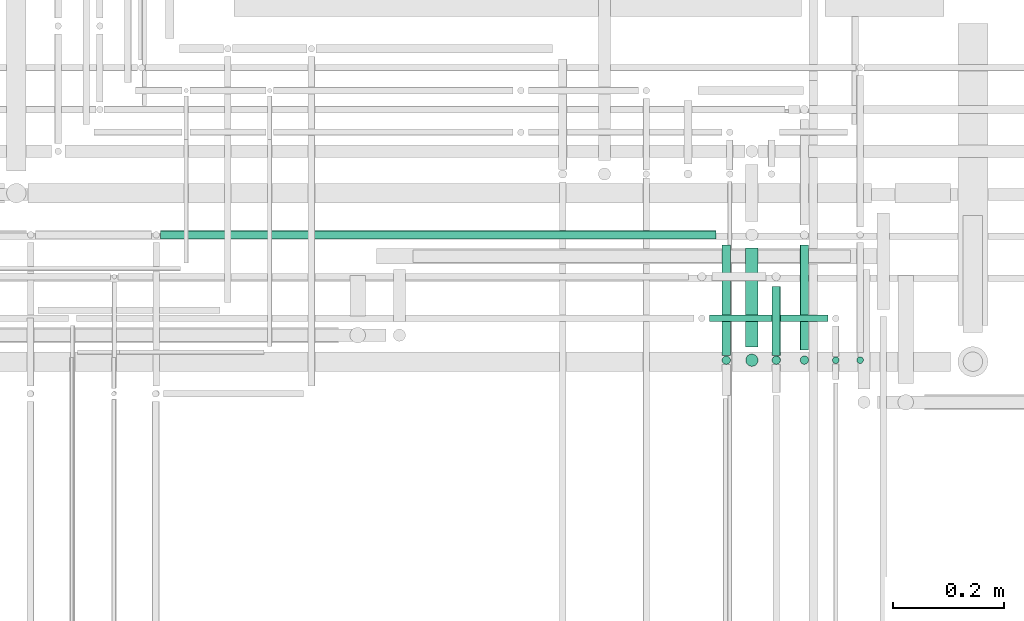
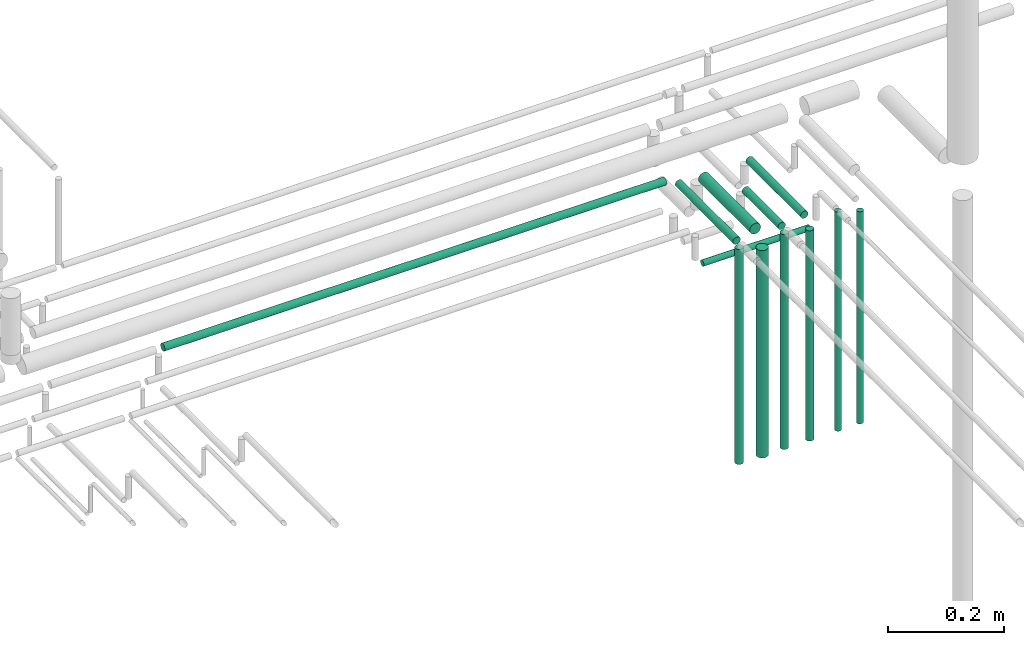
# One storey, part 222 of 331: 12 flow segments.
"""IFC2X3 building model written with IfcOpenShell, lengths in millimetres."""

from ifc_helpers import new_model, entity, si_unit, converted_unit, derived_unit, direction, frame, frame_2d, origin, origin_2d_with_axis, place, context, subcontext, project, spatial, circle, extrude, type_object, element, save


model = new_model("IFC2X3")

# Units and contexts
model_context = context("Model", 3, precision=0.01, world=origin(), true_north=direction((6.12303176911189e-17, 1.0)))
body_context = subcontext(model_context, "Body", "Model", "MODEL_VIEW")
ifc_project = project(units=[si_unit("LENGTHUNIT", "METRE", prefix="MILLI"), si_unit("AREAUNIT", "SQUARE_METRE"), si_unit("VOLUMEUNIT", "CUBIC_METRE"), converted_unit("PLANEANGLEUNIT", "DEGREE", entity("IfcRatioMeasure", 0.0174532925199433), si_unit("PLANEANGLEUNIT", "RADIAN"), dimensions=[0, 0, 0, 0, 0, 0, 0]), si_unit("MASSUNIT", "GRAM", prefix="KILO"), derived_unit("MASSDENSITYUNIT", [(si_unit("MASSUNIT", "GRAM", prefix="KILO"), 1), (si_unit("LENGTHUNIT", "METRE"), -3)]), derived_unit("MOMENTOFINERTIAUNIT", [(si_unit("LENGTHUNIT", "METRE"), 4)]), si_unit("TIMEUNIT", "SECOND"), si_unit("FREQUENCYUNIT", "HERTZ"), si_unit("THERMODYNAMICTEMPERATUREUNIT", "DEGREE_CELSIUS"), derived_unit("THERMALTRANSMITTANCEUNIT", [(si_unit("MASSUNIT", "GRAM", prefix="KILO"), 1), (si_unit("THERMODYNAMICTEMPERATUREUNIT", "KELVIN"), -1), (si_unit("TIMEUNIT", "SECOND"), -3)]), derived_unit("VOLUMETRICFLOWRATEUNIT", [(si_unit("LENGTHUNIT", "METRE"), 3), (si_unit("TIMEUNIT", "SECOND"), -1)]), derived_unit("MASSFLOWRATEUNIT", [(si_unit("MASSUNIT", "GRAM", prefix="KILO"), 1), (si_unit("TIMEUNIT", "SECOND"), -1)]), derived_unit("ROTATIONALFREQUENCYUNIT", [(si_unit("TIMEUNIT", "SECOND"), -1)]), si_unit("ELECTRICCURRENTUNIT", "AMPERE"), si_unit("ELECTRICVOLTAGEUNIT", "VOLT"), si_unit("POWERUNIT", "WATT"), si_unit("FORCEUNIT", "NEWTON", prefix="KILO"), si_unit("ILLUMINANCEUNIT", "LUX"), si_unit("LUMINOUSFLUXUNIT", "LUMEN"), si_unit("LUMINOUSINTENSITYUNIT", "CANDELA"), derived_unit("USERDEFINED", [(si_unit("MASSUNIT", "GRAM", prefix="KILO"), -1), (si_unit("LENGTHUNIT", "METRE"), -2), (si_unit("TIMEUNIT", "SECOND"), 3), (si_unit("LUMINOUSFLUXUNIT", "LUMEN"), 1)]), derived_unit("LINEARVELOCITYUNIT", [(si_unit("LENGTHUNIT", "METRE"), 1), (si_unit("TIMEUNIT", "SECOND"), -1)]), si_unit("PRESSUREUNIT", "PASCAL"), derived_unit("USERDEFINED", [(si_unit("LENGTHUNIT", "METRE"), -2), (si_unit("MASSUNIT", "GRAM", prefix="KILO"), 1), (si_unit("TIMEUNIT", "SECOND"), -2)]), derived_unit("LINEARFORCEUNIT", [(si_unit("MASSUNIT", "GRAM", prefix="KILO"), 1), (si_unit("LENGTHUNIT", "METRE"), 1), (si_unit("TIMEUNIT", "SECOND"), -2), (si_unit("LENGTHUNIT", "METRE"), -1)]), derived_unit("PLANARFORCEUNIT", [(si_unit("MASSUNIT", "GRAM", prefix="KILO"), 1), (si_unit("LENGTHUNIT", "METRE"), 1), (si_unit("TIMEUNIT", "SECOND"), -2), (si_unit("LENGTHUNIT", "METRE"), -2)])], contexts=[model_context])

# Site, building, storey
site_placement = place(None, frame((0.0, -0.00077364408347762, 0.0)))
site = spatial("IfcSite", under=ifc_project, at=site_placement, CompositionType="ELEMENT")
building_placement = place(site_placement, origin())
building = spatial("IfcBuilding", under=site, at=building_placement, CompositionType="ELEMENT")
storey_placement = place(building_placement, origin())
storey = spatial("IfcBuildingStorey", under=building, at=storey_placement, CompositionType="ELEMENT", Elevation=0.0)

# Flow segments
pipe_segment_type = type_object("IfcPipeSegmentType", PredefinedType="NOTDEFINED")
flow_segment_1_placement = place(storey_placement, frame((63502.5166110417, 8143.02529159144, 14090.0)))
element("IfcFlowSegment", 1, at=flow_segment_1_placement, inside=storey, type_object=pipe_segment_type, context=body_context, shape_type="SweptSolid", body=[
    extrude(circle(Radius=6.0, at=origin_2d_with_axis()), frame((7.59527223591454, 7.59527223591562, 0.0)), (0.0, 0.0, 1.0), 446.000000000003),
])
flow_segment_2_placement = place(storey_placement, frame((63239.9250896743, 8218.02529159144, 14465.4949923551)))
element("IfcFlowSegment", 2, at=flow_segment_2_placement, inside=storey, type_object=pipe_segment_type, context=body_context, shape_type="SweptSolid", body=[
    extrude(circle(Radius=6.0, at=frame_2d((-1.08286712929839e-12, -1.70713578218966e-41), x_axis=(1.0, 0.0))), frame((0.0, 7.59527223591454, 7.5952722359167), z_axis=(1.0, 0.0, 0.0), x_axis=(0.0, -1.0, 0.0)), (0.0, 0.0, 1.0), 212.543701506382),
])
flow_segment_3_placement = place(storey_placement, frame((63401.0132627126, 8168.62056382736, 14540.9047277641)))
element("IfcFlowSegment", 3, at=flow_segment_3_placement, inside=storey, type_object=pipe_segment_type, context=body_context, shape_type="SweptSolid", body=[
    extrude(circle(Radius=7.5, at=origin_2d_with_axis()), frame((9.09527223591419, 0.0, 9.09527223591636), z_axis=(0.0, 1.0, 0.0), x_axis=(-1.0, 0.0, 0.0)), (0.0, 0.0, 1.0), 189.000000000005),
])
flow_segment_4_placement = place(storey_placement, frame((63401.0132627126, 8141.52529159144, 14090.0)))
element("IfcFlowSegment", 4, at=flow_segment_4_placement, inside=storey, type_object=pipe_segment_type, context=body_context, shape_type="SweptSolid", body=[
    extrude(circle(Radius=7.5, at=origin_2d_with_axis()), frame((9.09527223591419, 9.09527223591636, 0.0)), (0.0, 0.0, 1.0), 442.000000000008),
])
flow_segment_5_placement = place(storey_placement, frame((63458.8735189448, 8143.02529159144, 14090.0)))
element("IfcFlowSegment", 5, at=flow_segment_5_placement, inside=storey, type_object=pipe_segment_type, context=body_context, shape_type="SweptSolid", body=[
    extrude(circle(Radius=6.0, at=origin_2d_with_axis()), frame((7.59527223591454, 7.59527223591562, 0.0)), (0.0, 0.0, 1.0), 460.387412624587),
])
flow_segment_6_placement = place(storey_placement, frame((63350.2977870341, 8141.52529159145, 14089.9934539411)))
element("IfcFlowSegment", 6, at=flow_segment_6_placement, inside=storey, type_object=pipe_segment_type, context=body_context, shape_type="SweptSolid", body=[
    extrude(circle(Radius=7.5, at=origin_2d_with_axis()), frame((9.48977868385045, 9.09527223591636, 0.00654605893170697), z_axis=(-0.00087280785761852, 0.0, 0.999999619103149), x_axis=(0.999999619103149, 0.0, 0.00087280785761852)), (0.0, 0.0, 1.0), 452.000175316315),
])
flow_segment_7_placement = place(storey_placement, frame((63350.2906839002, 8158.62056382736, 14540.9047277641)))
element("IfcFlowSegment", 7, at=flow_segment_7_placement, inside=storey, type_object=pipe_segment_type, context=body_context, shape_type="SweptSolid", body=[
    extrude(circle(Radius=7.5, at=frame_2d((-8.66293703438714e-12, 0.0), x_axis=(1.0, 0.0))), frame((9.09527223590553, 0.0, 9.09527223591636), z_axis=(0.0, 1.0, 0.0), x_axis=(-1.0, 0.0, 0.0)), (0.0, 0.0, 1.0), 123.999999999995),
])
flow_segment_8_placement = place(storey_placement, frame((63303.2157915365, 8174.62056382735, 14537.4047277641)))
element("IfcFlowSegment", 8, at=flow_segment_8_placement, inside=storey, type_object=pipe_segment_type, context=body_context, shape_type="SweptSolid", body=[
    extrude(circle(Radius=11.0, at=frame_2d((0.0, -2.16573425859679e-12), x_axis=(1.0, 0.0))), frame((12.5952722359134, 0.0, 12.5952722359177), z_axis=(0.0, 1.0, 0.0), x_axis=(-1.0, 0.0, 0.0)), (0.0, 0.0, 1.0), 177.000000000017),
])
flow_segment_9_placement = place(storey_placement, frame((63260.6765027261, 8158.62056382735, 14541.2921403887)))
element("IfcFlowSegment", 9, at=flow_segment_9_placement, inside=storey, type_object=pipe_segment_type, context=body_context, shape_type="SweptSolid", body=[
    extrude(circle(Radius=7.5, at=origin_2d_with_axis()), frame((9.09527223591419, 0.0, 9.09527223591636), z_axis=(0.0, 1.0, 0.0), x_axis=(1.0, 0.0, 0.0)), (0.0, 0.0, 1.0), 199.000000000001),
])
flow_segment_10_placement = place(storey_placement, frame((63303.2157915365, 8138.02529159144, 14090.0)))
element("IfcFlowSegment", 10, at=flow_segment_10_placement, inside=storey, type_object=pipe_segment_type, context=body_context, shape_type="SweptSolid", body=[
    extrude(circle(Radius=11.0, at=origin_2d_with_axis()), frame((12.5952722359134, 12.5952722359156, 0.0)), (0.0, 0.0, 1.0), 436.000000000007),
])
flow_segment_11_placement = place(storey_placement, frame((63260.6765027261, 8141.52529159143, 14090.0)))
element("IfcFlowSegment", 11, at=flow_segment_11_placement, inside=storey, type_object=pipe_segment_type, context=body_context, shape_type="SweptSolid", body=[
    extrude(circle(Radius=7.5, at=origin_2d_with_axis()), frame((9.09527223591419, 9.09527223591636, 0.0)), (0.0, 0.0, 1.0), 451.999999999995),
])
flow_segment_12_placement = place(storey_placement, frame((62254.1177906274, 8366.52529159144, 14541.2921403887)))
element("IfcFlowSegment", 12, at=flow_segment_12_placement, inside=storey, type_object=pipe_segment_type, context=body_context, shape_type="SweptSolid", body=[
    extrude(circle(Radius=7.5, at=origin_2d_with_axis()), frame((0.0, 9.09527223591636, 9.09527223591636), z_axis=(1.0, 0.0, 0.0), x_axis=(0.0, 1.0, 0.0)), (0.0, 0.0, 1.0), 997.653984334645),
])

save(model, "model.ifc")
